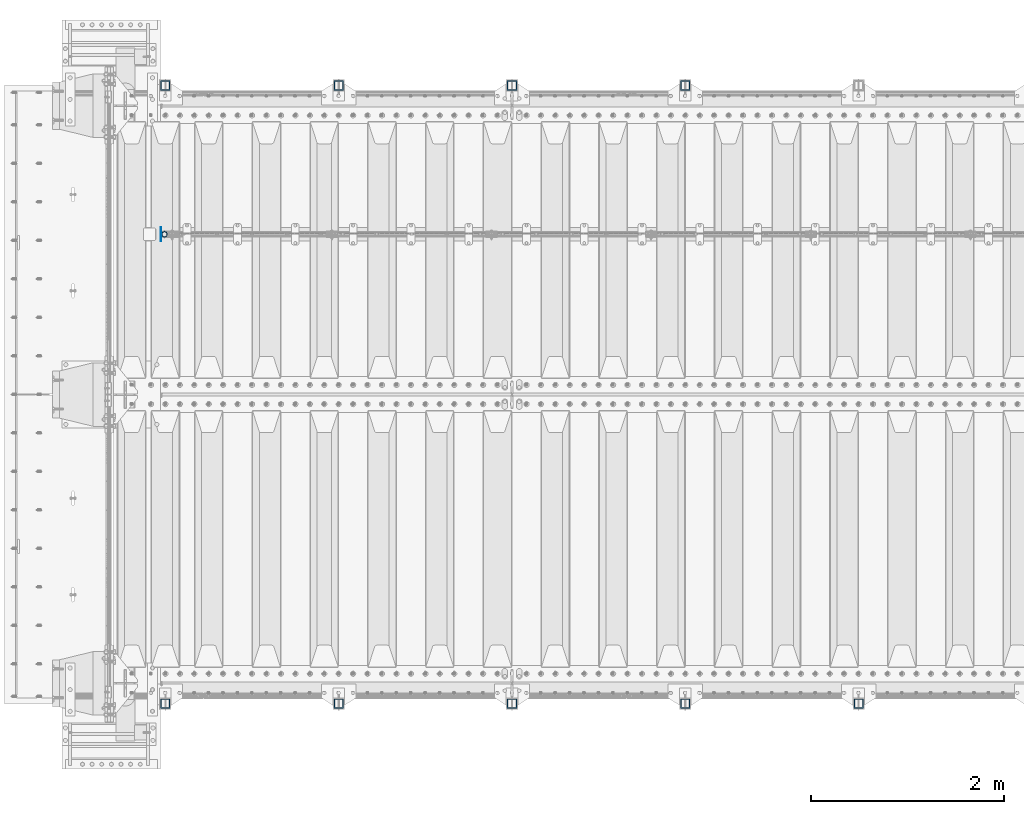
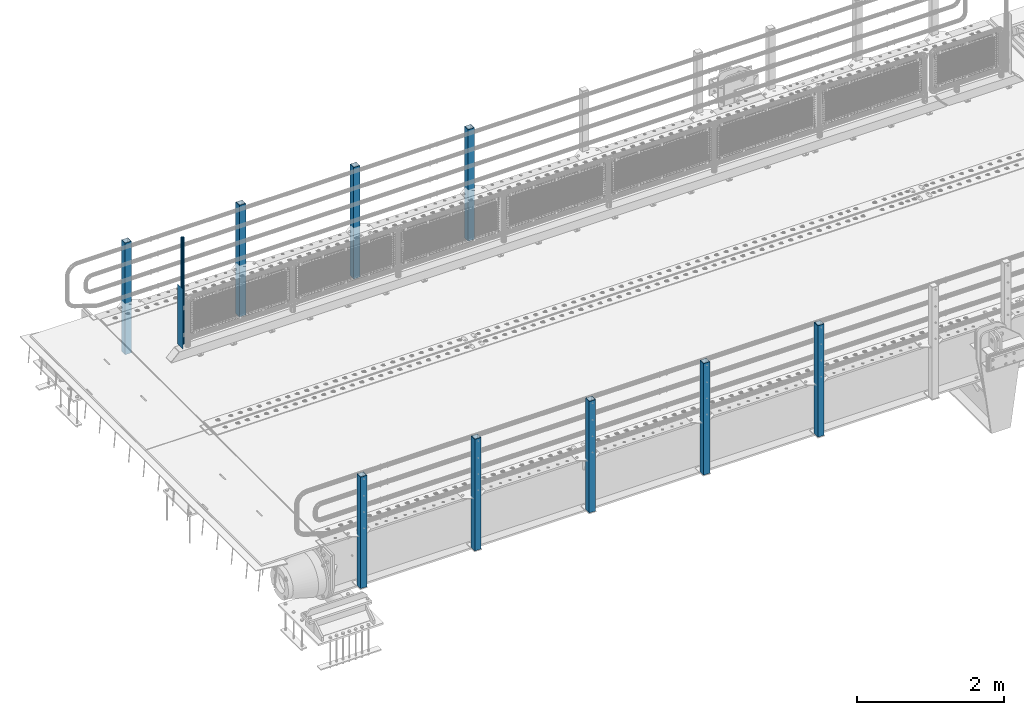
# One storey, part 49 of 193: 11 columns.
"""IFC2X3 building model written with IfcOpenShell, lengths in millimetres."""

from ifc_helpers import new_model, si_unit, frame, origin_with_axes, place, context, subcontext, project, spatial, faceted_brep, material, type_object, element, save


model = new_model("IFC2X3")

# Units and contexts
model_context = context("Model", 3, precision=1e-05, world=origin_with_axes())
body_context = subcontext(model_context, "Body", "Model", "MODEL_VIEW")
ifc_project = project(units=[si_unit("LENGTHUNIT", "METRE", prefix="MILLI"), si_unit("AREAUNIT", "SQUARE_METRE"), si_unit("VOLUMEUNIT", "CUBIC_METRE"), si_unit("MASSUNIT", "GRAM", prefix="KILO"), si_unit("TIMEUNIT", "SECOND"), si_unit("PLANEANGLEUNIT", "RADIAN"), si_unit("SOLIDANGLEUNIT", "STERADIAN"), si_unit("THERMODYNAMICTEMPERATUREUNIT", "DEGREE_CELSIUS"), si_unit("LUMINOUSINTENSITYUNIT", "LUMEN")], contexts=[model_context])

# Site, building, storey
site_placement = place(None, origin_with_axes())
site = spatial("IfcSite", under=ifc_project, at=site_placement, CompositionType="ELEMENT")
building_placement = place(site_placement, origin_with_axes())
building = spatial("IfcBuilding", under=site, at=building_placement, Name="Standard", CompositionType="ELEMENT")
storey_placement = place(building_placement, origin_with_axes())
storey = spatial("IfcBuildingStorey", under=building, at=storey_placement, Name="Undefined", CompositionType="ELEMENT", Elevation=0.0)

# Columns
ifc_material_1 = material(Name="Misc_Undefined")
column_type_1 = type_object("IfcColumnType", PredefinedType="NOTDEFINED")
column_1_placement = place(storey_placement, frame((-41909.0, 28664.5, 238.02), z_axis=(1.0, 0.0, 0.0), x_axis=(0.0, 0.0, 1.0)))
element("IfcColumn", 1, at=column_1_placement, inside=storey, type_object=column_type_1, material=ifc_material_1, context=body_context, shape_type="Brep", body=[
    faceted_brep([(0.0, -25.3499999999985, 0.0), (0.0, -23.4203461491597, 9.70102501045403), (1761.98, -23.4203461491597, 9.70102501045403), (1761.98, -25.3499999999985, 0.0), (0.0, -17.9251569030785, 17.9251569030785), (1761.98, -17.9251569030785, 17.9251569030785), (0.0, -9.70102501045403, 23.4203461491597), (1761.98, -9.70102501045403, 23.4203461491597), (0.0, 0.0, 25.3499999999985), (1761.98, 0.0, 25.3499999999985), (0.0, 9.70102501045403, 23.4203461491597), (1761.98, 9.70102501045403, 23.4203461491597), (0.0, 17.9251569030785, 17.9251569030785), (1761.98, 17.9251569030785, 17.9251569030785), (0.0, 23.4203461491597, 9.70102501045403), (1761.98, 23.4203461491597, 9.70102501045403), (0.0, 25.3499999999985, 0.0), (1761.98, 25.3499999999985, 0.0), (0.0, 23.4203461491597, -9.70102501045403), (1761.98, 23.4203461491597, -9.70102501045403), (0.0, 17.9251569030785, -17.9251569030785), (1761.98, 17.9251569030785, -17.9251569030785), (0.0, 9.70102501045403, -23.4203461491597), (1761.98, 9.70102501045403, -23.4203461491597), (0.0, 0.0, -25.3499999999985), (1761.98, 0.0, -25.3499999999985), (0.0, -9.70102501045403, -23.4203461491597), (1761.98, -9.70102501045403, -23.4203461491597), (0.0, -17.9251569030785, -17.9251569030785), (1761.98, -17.9251569030785, -17.9251569030785), (0.0, -23.4203461491597, -9.70102501045403), (1761.98, -23.4203461491597, -9.70102501045403), (0.0, -30.1500000000015, 0.0), (0.0, -27.8549679052157, -11.5379054858058), (1761.98, -27.8549679052157, -11.5379054858058), (1761.98, -30.1500000000015, 0.0), (0.0, -21.3192694527752, -21.3192694527752), (1761.98, -21.3192694527752, -21.3192694527752), (0.0, -11.5379054858058, -27.8549679052157), (1761.98, -11.5379054858058, -27.8549679052157), (0.0, 0.0, -30.1500000000015), (1761.98, 0.0, -30.1500000000015), (0.0, 11.5379054858058, -27.8549679052157), (1761.98, 11.5379054858058, -27.8549679052157), (0.0, 21.3192694527752, -21.3192694527752), (1761.98, 21.3192694527752, -21.3192694527752), (0.0, 27.8549679052157, -11.5379054858058), (1761.98, 27.8549679052157, -11.5379054858058), (0.0, 30.1500000000015, 0.0), (1761.98, 30.1500000000015, 0.0), (0.0, 27.8549679052157, 11.5379054858058), (1761.98, 27.8549679052157, 11.5379054858058), (0.0, 21.3192694527752, 21.3192694527752), (1761.98, 21.3192694527752, 21.3192694527752), (0.0, 11.5379054858058, 27.8549679052157), (1761.98, 11.5379054858058, 27.8549679052157), (0.0, 0.0, 30.1500000000015), (1761.98, 0.0, 30.1500000000015), (0.0, -11.5379054858058, 27.8549679052157), (1761.98, -11.5379054858058, 27.8549679052157), (0.0, -21.3192694527752, 21.3192694527752), (1761.98, -21.3192694527752, 21.3192694527752), (0.0, -27.8549679052157, 11.5379054858058), (1761.98, -27.8549679052157, 11.5379054858058)], [[[0, 1, 2, 3]], [[1, 4, 5, 2]], [[4, 6, 7, 5]], [[6, 8, 9, 7]], [[8, 10, 11, 9]], [[10, 12, 13, 11]], [[12, 14, 15, 13]], [[14, 16, 17, 15]], [[16, 18, 19, 17]], [[18, 20, 21, 19]], [[20, 22, 23, 21]], [[22, 24, 25, 23]], [[24, 26, 27, 25]], [[26, 28, 29, 27]], [[28, 30, 31, 29]], [[30, 0, 3, 31]], [[32, 33, 34, 35]], [[33, 36, 37, 34]], [[36, 38, 39, 37]], [[38, 40, 41, 39]], [[40, 42, 43, 41]], [[42, 44, 45, 43]], [[44, 46, 47, 45]], [[46, 48, 49, 47]], [[48, 50, 51, 49]], [[50, 52, 53, 51]], [[52, 54, 55, 53]], [[54, 56, 57, 55]], [[56, 58, 59, 57]], [[58, 60, 61, 59]], [[60, 62, 63, 61]], [[62, 32, 35, 63]], [[37, 39, 41, 43, 45, 47, 49, 51, 53, 55, 57, 59, 61, 63, 35, 34], [5, 7, 9, 11, 13, 15, 17, 19, 21, 23, 25, 27, 29, 31, 3, 2]], [[62, 60, 58, 56, 54, 52, 50, 48, 46, 44, 42, 40, 38, 36, 33, 32], [30, 28, 26, 24, 22, 20, 18, 16, 14, 12, 10, 8, 6, 4, 1, 0]]]),
])
ifc_material_2 = material()
column_type_2 = type_object("IfcColumnType", PredefinedType="NOTDEFINED")
for number, where, z_axis, x_axis in (
    (2, (-36499.9999999999, 30210.0000000002, -844.999999999998), (0.0, -1.0, 0.0), (0.0, 0.0, 1.0)),
    (3, (-38299.9999999999, 30210.0000000002, -844.999999999998), (0.0, -1.0, 0.0), (0.0, 0.0, 1.0)),
    (4, (-40099.9999999999, 30210.0000000002, -844.999999999998), (0.0, -1.0, 0.0), (0.0, 0.0, 1.0)),
    (5, (-41899.9999999999, 30210.0000000002, -844.999999999998), (0.0, -1.0, 0.0), (0.0, 0.0, 1.0)),
    (6, (-34700.0000000001, 23789.9999999998, -844.999999999998), (0.0, 1.0, 0.0), (0.0, 0.0, 1.0)),
    (7, (-36500.0000000001, 23789.9999999998, -844.999999999998), (0.0, 1.0, 0.0), (0.0, 0.0, 1.0)),
    (8, (-38300.0000000001, 23789.9999999998, -844.999999999998), (0.0, 1.0, 0.0), (0.0, 0.0, 1.0)),
    (9, (-40100.0000000001, 23789.9999999998, -844.999999999998), (0.0, 1.0, 0.0), (0.0, 0.0, 1.0)),
    (10, (-41900.0000000001, 23789.9999999998, -844.999999999998), (0.0, 1.0, 0.0), (0.0, 0.0, 1.0)),
):
    element("IfcColumn", number, at=place(storey_placement, frame(where, z_axis=z_axis, x_axis=x_axis)), inside=storey, type_object=column_type_2, material=ifc_material_2, context=body_context, shape_type="Brep", body=[
        faceted_brep([(0.0, 40.0, -40.0), (0.0, -40.0, -40.0), (1855.0, -40.0, -40.0), (1855.0, 40.0, -40.0), (0.0, -40.0, 40.0), (1855.0, -40.0, 40.0), (0.0, 40.0, 40.0), (1855.0, 40.0, 40.0), (0.0, 50.0, -50.0), (0.0, 50.0, 50.0), (1855.0, 50.0, 50.0), (1855.0, 50.0, -50.0), (0.0, -50.0, 50.0), (1855.0, -50.0, 50.0), (0.0, -50.0, -50.0), (1855.0, -50.0, -50.0)], [[[0, 1, 2, 3]], [[1, 4, 5, 2]], [[4, 6, 7, 5]], [[6, 0, 3, 7]], [[8, 9, 10, 11]], [[9, 12, 13, 10]], [[12, 14, 15, 13]], [[14, 8, 11, 15]], [[13, 15, 11, 10], [5, 7, 3, 2]], [[14, 12, 9, 8], [6, 4, 1, 0]]]),
    ])
column_type_3 = type_object("IfcColumnType", PredefinedType="NOTDEFINED")
column_2_placement = place(storey_placement, frame((-41945.5, 28664.5, 200.0), z_axis=(0.0, 1.0, 0.0), x_axis=(0.0, 0.0, 1.0)))
element("IfcColumn", 11, at=column_2_placement, inside=storey, type_object=column_type_3, material=ifc_material_1, context=body_context, shape_type="Brep", body=[
    faceted_brep([(0.0, 1.5, -75.0), (0.0, 1.5, 75.0), (1000.0, 1.5, 75.0), (1000.0, 1.5, -75.0), (0.0, -1.5, 75.0), (1000.0, -1.5, 75.0), (0.0, -1.5, -75.0), (1000.0, -1.5, -75.0)], [[[0, 1, 2, 3]], [[1, 4, 5, 2]], [[4, 6, 7, 5]], [[6, 0, 3, 7]], [[5, 7, 3, 2]], [[6, 4, 1, 0]]]),
])

save(model, "model.ifc")
